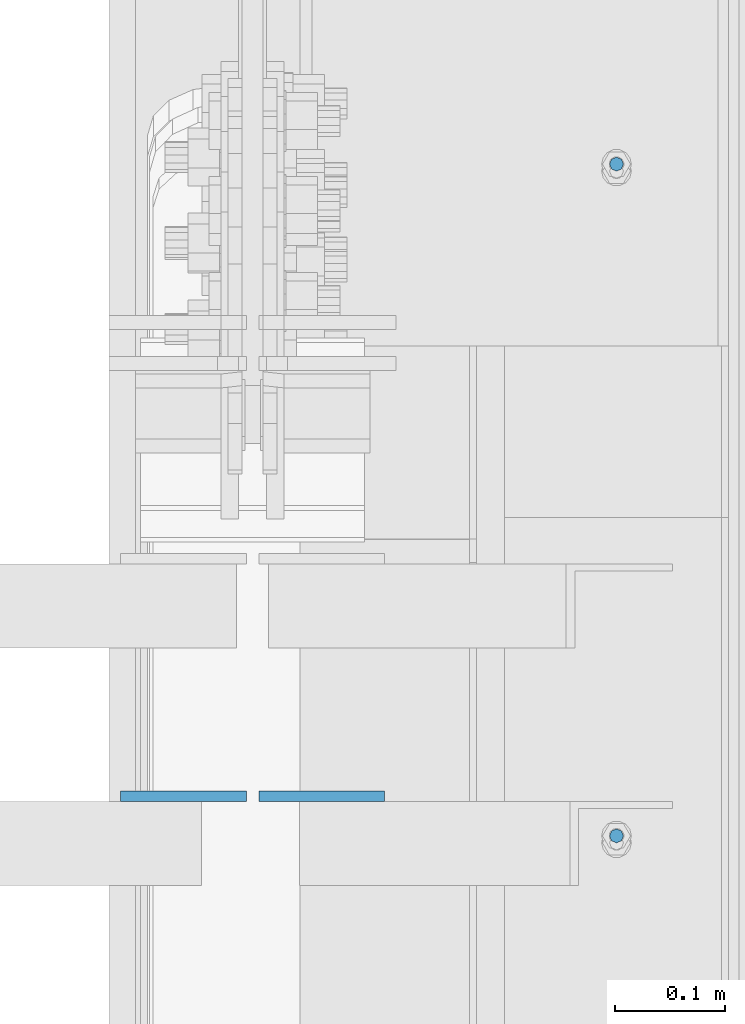
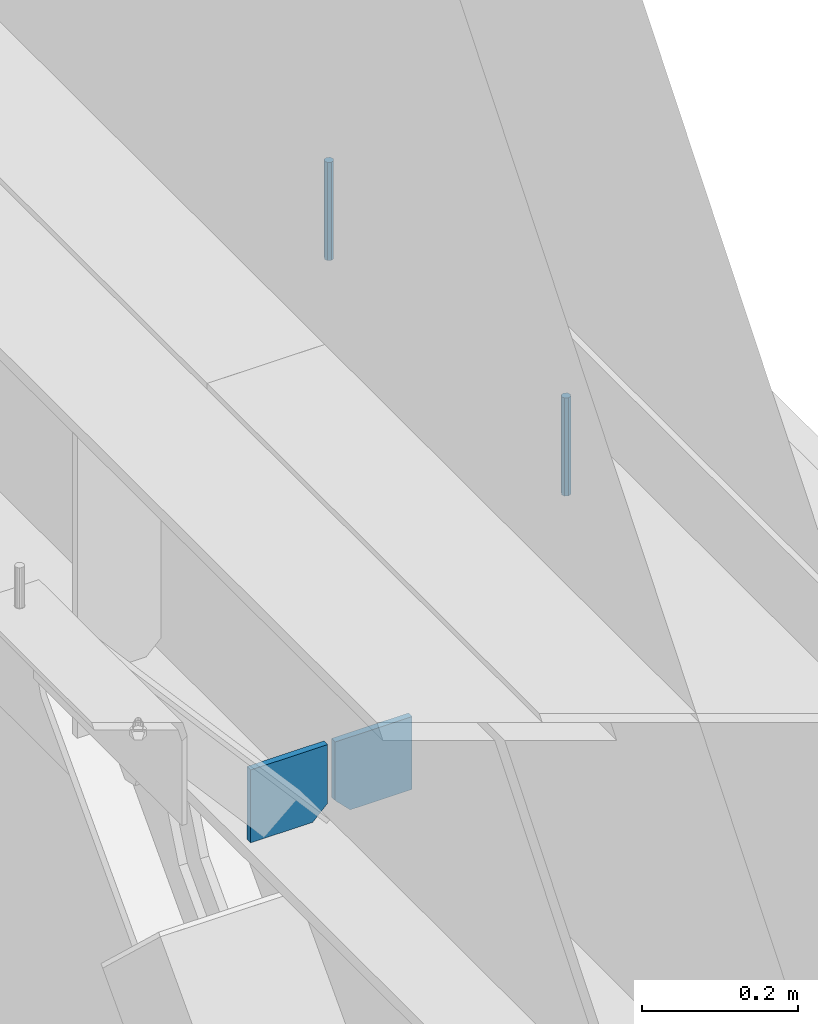
# One storey, part 473 of 1179: 4 columns, 1 element without a shape of its own.
"""IFC2X3 building model written with IfcOpenShell, lengths in millimetres."""

from ifc_helpers import new_model, si_unit, frame, origin_with_axes, place, context, subcontext, project, spatial, faceted_brep, material, type_object, element, aggregate, save


model = new_model("IFC2X3")

# Units and contexts
model_context = context("Model", 3, precision=1e-05, world=origin_with_axes())
body_context = subcontext(model_context, "Body", "Model", "MODEL_VIEW")
ifc_project = project(units=[si_unit("LENGTHUNIT", "METRE", prefix="MILLI"), si_unit("AREAUNIT", "SQUARE_METRE"), si_unit("VOLUMEUNIT", "CUBIC_METRE"), si_unit("MASSUNIT", "GRAM", prefix="KILO"), si_unit("TIMEUNIT", "SECOND"), si_unit("PLANEANGLEUNIT", "RADIAN"), si_unit("SOLIDANGLEUNIT", "STERADIAN"), si_unit("THERMODYNAMICTEMPERATUREUNIT", "DEGREE_CELSIUS"), si_unit("LUMINOUSINTENSITYUNIT", "LUMEN")], contexts=[model_context])

# Site, building, storey
site_placement = place(None, origin_with_axes())
site = spatial("IfcSite", under=ifc_project, at=site_placement, CompositionType="ELEMENT")
building_placement = place(site_placement, origin_with_axes())
building = spatial("IfcBuilding", under=site, at=building_placement, Name="Undefined", CompositionType="ELEMENT")
storey_placement = place(building_placement, origin_with_axes())
storey = spatial("IfcBuildingStorey", under=building, at=storey_placement, Name="Undefined", CompositionType="ELEMENT", Elevation=0.0)

# Assembly, columns
assembly_placement = place(storey_placement, origin_with_axes())
assembly = element("IfcElementAssembly", 1, at=assembly_placement, inside=storey, Name="BEAM", AssemblyPlace="NOTDEFINED", PredefinedType="RIGID_FRAME")
ifc_material_1 = material(Name="STEEL/A36")
column_type_1 = type_object("IfcColumnType", PredefinedType="NOTDEFINED")
column_1_placement = place(assembly_placement, frame((24245.09375, 29849.1463232685, 7613.65), z_axis=(1.0, 0.0, 0.0), x_axis=(0.0, 0.0, 1.0)))
column_1 = element("IfcColumn", 2, at=column_1_placement, type_object=column_type_1, material=ifc_material_1, Name="PLATE", context=body_context, shape_type="Brep", body=[
    faceted_brep([(22.2250000000004, 4.76250000000073, 57.1500000000015), (0.0, 4.76250000000073, 34.9249999999993), (0.0, -4.76250000000073, 34.9249999999993), (22.2250000000004, -4.76250000000073, 57.1500000000015), (114.300000000001, 4.76250000000073, 57.1500000000015), (114.300000000001, 4.76250000000073, -57.1500000000015), (0.0, 4.76250000000073, -57.1500000000015), (114.300000000001, -4.76250000000073, 57.1500000000015), (0.0, -4.76250000000073, -57.1500000000015), (114.300000000001, -4.76250000000073, -57.1500000000015)], [[[0, 1, 2, 3]], [[4, 5, 6, 1, 0]], [[7, 4, 0, 3]], [[8, 9, 7, 3, 2]], [[8, 6, 5, 9]], [[7, 9, 5, 4]], [[6, 8, 2, 1]]]),
])
column_2_placement = place(assembly_placement, frame((24370.50625, 29849.1463232685, 7613.65), z_axis=(-1.0, 0.0, 0.0), x_axis=(0.0, 0.0, 1.0)))
column_2 = element("IfcColumn", 3, at=column_2_placement, type_object=column_type_1, material=ifc_material_1, Name="PLATE", context=body_context, shape_type="Brep", body=[
    faceted_brep([(22.2250000000004, 4.76250000000073, 57.1500000000015), (0.0, 4.76250000000073, 34.9249999999993), (0.0, -4.76250000000073, 34.9249999999993), (22.2250000000004, -4.76250000000073, 57.1500000000015), (114.300000000001, 4.76250000000073, 57.1500000000015), (114.300000000001, 4.76250000000073, -57.1500000000015), (0.0, 4.76250000000073, -57.1500000000015), (114.300000000001, -4.76250000000073, 57.1500000000015), (0.0, -4.76250000000073, -57.1500000000015), (114.300000000001, -4.76250000000073, -57.1500000000015)], [[[0, 1, 2, 3]], [[4, 5, 6, 1, 0]], [[7, 4, 0, 3]], [[8, 9, 7, 3, 2]], [[8, 6, 5, 9]], [[7, 9, 5, 4]], [[6, 8, 2, 1]]]),
])
ifc_material_2 = material(Name="STEEL/A307")
column_type_2 = type_object("IfcColumnType", PredefinedType="NOTDEFINED")
column_3_placement = place(assembly_placement, frame((24638.0000051215, 30422.8500001664, 8023.22499553788), z_axis=(0.0, 1.0, 0.0), x_axis=(0.0, 0.0, 1.0)))
column_3 = element("IfcColumn", 4, at=column_3_placement, type_object=column_type_2, material=ifc_material_2, Name="THREADED ROD", context=body_context, shape_type="Brep", body=[
    faceted_brep([(0.0, -6.34999999999854, 0.0), (0.0, -4.49012806053361, -4.49012806053452), (153.987504462122, -4.49012806053361, -4.49012806053361), (153.987504462122, -6.34999999999854, 0.0), (0.0, 0.0, -6.34999999999991), (153.987504462122, 0.0, -6.34999999999854), (0.0, 4.49012806053361, -4.49012806053452), (153.987504462122, 4.49012806053361, -4.49012806053361), (0.0, 6.34999999999854, 0.0), (153.987504462122, 6.34999999999854, 0.0), (0.0, 4.49012806053361, 4.49012806053452), (153.987504462122, 4.49012806053361, 4.49012806053361), (0.0, 0.0, 6.34999999999991), (153.987504462122, 0.0, 6.34999999999854), (0.0, -4.49012806053361, 4.49012806053452), (153.987504462122, -4.49012806053361, 4.49012806053361)], [[[0, 1, 2, 3]], [[1, 4, 5, 2]], [[4, 6, 7, 5]], [[6, 8, 9, 7]], [[8, 10, 11, 9]], [[10, 12, 13, 11]], [[12, 14, 15, 13]], [[14, 0, 3, 15]], [[5, 7, 9, 11, 13, 15, 3, 2]], [[14, 12, 10, 8, 6, 4, 1, 0]]]),
])
column_4_placement = place(assembly_placement, frame((24638.0000051215, 29813.2500001664, 8023.22499553788), z_axis=(0.0, 1.0, 0.0), x_axis=(0.0, 0.0, 1.0)))
column_4 = element("IfcColumn", 5, at=column_4_placement, type_object=column_type_2, material=ifc_material_2, Name="THREADED ROD", context=body_context, shape_type="Brep", body=[
    faceted_brep([(0.0, -6.34999999999854, 0.0), (0.0, -4.49012806053361, -4.49012806053452), (153.987504462122, -4.49012806053361, -4.49012806053361), (153.987504462122, -6.34999999999854, 0.0), (0.0, 0.0, -6.34999999999991), (153.987504462122, 0.0, -6.34999999999854), (0.0, 4.49012806053361, -4.49012806053452), (153.987504462122, 4.49012806053361, -4.49012806053361), (0.0, 6.34999999999854, 0.0), (153.987504462122, 6.34999999999854, 0.0), (0.0, 4.49012806053361, 4.49012806053452), (153.987504462122, 4.49012806053361, 4.49012806053361), (0.0, 0.0, 6.34999999999991), (153.987504462122, 0.0, 6.34999999999854), (0.0, -4.49012806053361, 4.49012806053452), (153.987504462122, -4.49012806053361, 4.49012806053361)], [[[0, 1, 2, 3]], [[1, 4, 5, 2]], [[4, 6, 7, 5]], [[6, 8, 9, 7]], [[8, 10, 11, 9]], [[10, 12, 13, 11]], [[12, 14, 15, 13]], [[14, 0, 3, 15]], [[5, 7, 9, 11, 13, 15, 3, 2]], [[14, 12, 10, 8, 6, 4, 1, 0]]]),
])
aggregate(assembly, [column_1, column_2, column_3, column_4])

save(model, "model.ifc")
